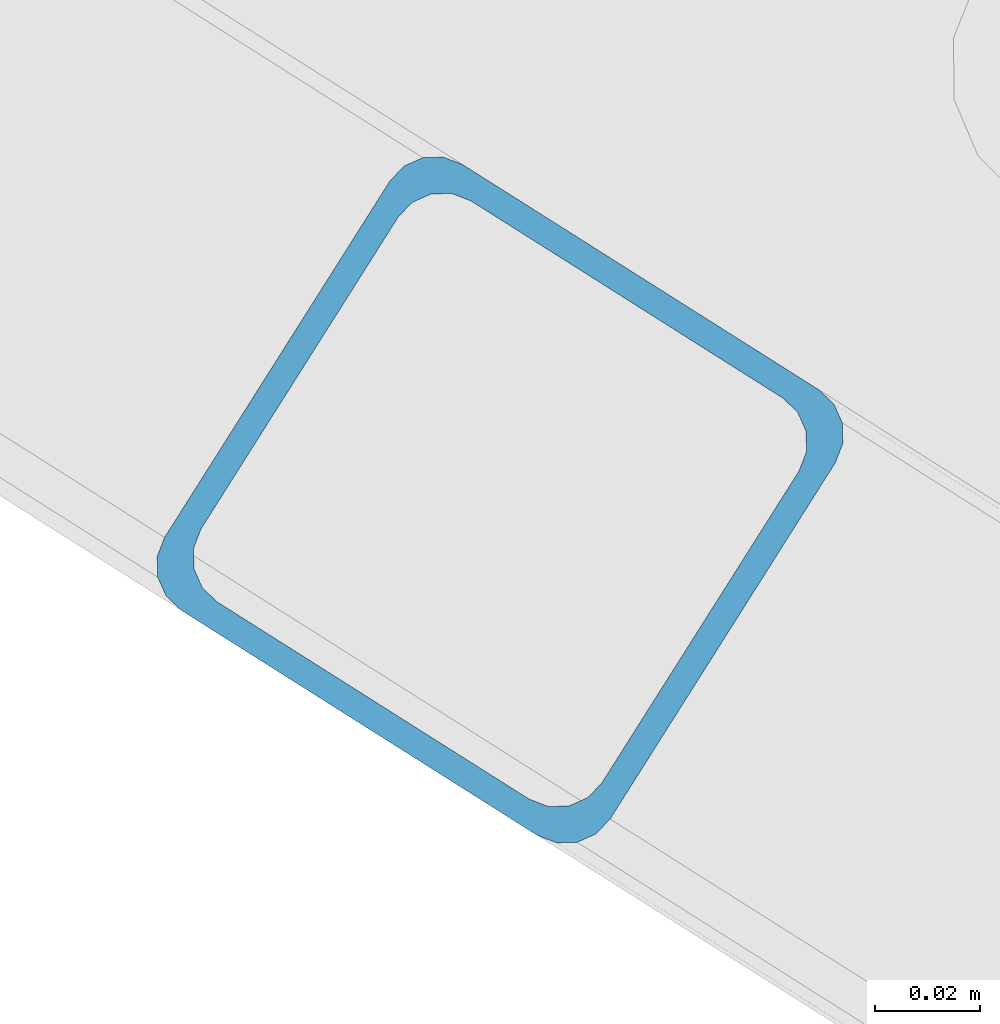
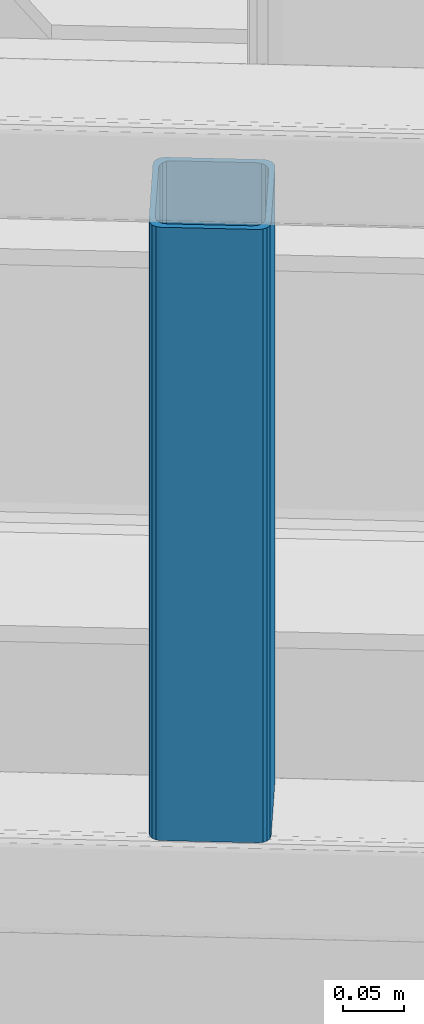
# One storey, part 12 of 92: 1 column.
"""IFC4 building model written with IfcOpenShell, lengths in millimetres."""

from ifc_helpers import new_model, entity, si_unit, converted_unit, derived_unit, direction, frame, origin, place, context, subcontext, project, spatial, indexed_curve, outline, extrude, type_object, element, save


model = new_model("IFC4")

# Units and contexts
model_context = context("Model", 3, precision=0.01, world=origin(), true_north=direction((6.12303176911189e-17, 1.0)))
plan_context = context("Plan", 3, precision=0.01, world=origin(), true_north=direction((6.12303176911189e-17, 1.0)))
body_context = subcontext(model_context, "Body", "Model", "MODEL_VIEW")
ifc_project = project(units=[si_unit("LENGTHUNIT", "METRE", prefix="MILLI"), si_unit("AREAUNIT", "SQUARE_METRE"), si_unit("VOLUMEUNIT", "CUBIC_METRE"), converted_unit("PLANEANGLEUNIT", "DEGREE", entity("IfcRatioMeasure", 0.0174532925199433), si_unit("PLANEANGLEUNIT", "RADIAN"), dimensions=[0, 0, 0, 0, 0, 0, 0]), si_unit("MASSUNIT", "GRAM", prefix="KILO"), derived_unit("MASSDENSITYUNIT", [(si_unit("MASSUNIT", "GRAM", prefix="KILO"), 1), (si_unit("LENGTHUNIT", "METRE"), -3)]), derived_unit("MOMENTOFINERTIAUNIT", [(si_unit("LENGTHUNIT", "METRE"), 4)]), si_unit("TIMEUNIT", "SECOND"), si_unit("FREQUENCYUNIT", "HERTZ"), si_unit("THERMODYNAMICTEMPERATUREUNIT", "DEGREE_CELSIUS"), derived_unit("THERMALTRANSMITTANCEUNIT", [(si_unit("MASSUNIT", "GRAM", prefix="KILO"), 1), (si_unit("THERMODYNAMICTEMPERATUREUNIT", "KELVIN"), -1), (si_unit("TIMEUNIT", "SECOND"), -3)]), derived_unit("VOLUMETRICFLOWRATEUNIT", [(si_unit("LENGTHUNIT", "METRE"), 3), (si_unit("TIMEUNIT", "SECOND"), -1)]), derived_unit("MASSFLOWRATEUNIT", [(si_unit("MASSUNIT", "GRAM", prefix="KILO"), 1), (si_unit("TIMEUNIT", "SECOND"), -1)]), derived_unit("ROTATIONALFREQUENCYUNIT", [(si_unit("TIMEUNIT", "SECOND"), -1)]), si_unit("ELECTRICCURRENTUNIT", "AMPERE"), si_unit("ELECTRICVOLTAGEUNIT", "VOLT"), si_unit("POWERUNIT", "WATT"), si_unit("FORCEUNIT", "NEWTON", prefix="KILO"), si_unit("ILLUMINANCEUNIT", "LUX"), si_unit("LUMINOUSFLUXUNIT", "LUMEN"), si_unit("LUMINOUSINTENSITYUNIT", "CANDELA"), derived_unit("USERDEFINED", [(si_unit("MASSUNIT", "GRAM", prefix="KILO"), -1), (si_unit("LENGTHUNIT", "METRE"), -2), (si_unit("TIMEUNIT", "SECOND"), 3), (si_unit("LUMINOUSFLUXUNIT", "LUMEN"), 1)]), derived_unit("LINEARVELOCITYUNIT", [(si_unit("LENGTHUNIT", "METRE"), 1), (si_unit("TIMEUNIT", "SECOND"), -1)]), si_unit("PRESSUREUNIT", "PASCAL"), derived_unit("USERDEFINED", [(si_unit("LENGTHUNIT", "METRE"), -2), (si_unit("MASSUNIT", "GRAM", prefix="KILO"), 1), (si_unit("TIMEUNIT", "SECOND"), -2)]), derived_unit("LINEARFORCEUNIT", [(si_unit("MASSUNIT", "GRAM", prefix="KILO"), 1), (si_unit("LENGTHUNIT", "METRE"), 1), (si_unit("TIMEUNIT", "SECOND"), -2), (si_unit("LENGTHUNIT", "METRE"), -1)]), derived_unit("PLANARFORCEUNIT", [(si_unit("MASSUNIT", "GRAM", prefix="KILO"), 1), (si_unit("LENGTHUNIT", "METRE"), 1), (si_unit("TIMEUNIT", "SECOND"), -2), (si_unit("LENGTHUNIT", "METRE"), -2)])], contexts=[model_context, plan_context])

# Site, building, storey
site_placement = place(None, origin())
site = spatial("IfcSite", under=ifc_project, at=site_placement, CompositionType="ELEMENT")
building_placement = place(site_placement, origin())
building = spatial("IfcBuilding", under=site, at=building_placement, CompositionType="ELEMENT")
storey_placement = place(building_placement, frame((0.0, 0.0, 15900.0)))
storey = spatial("IfcBuildingStorey", under=building, at=storey_placement, Name="05", CompositionType="ELEMENT", Elevation=15900.0)

# Column
column_type = type_object("IfcColumnType", PredefinedType="COLUMN")
column_placement = place(storey_placement, origin())
element("IfcColumn", 1, at=column_placement, inside=storey, type_object=column_type, ObjectType="Steel Column", PredefinedType="COLUMN", context=body_context, shape_type="SweptSolid", body=[
    extrude(outline(indexed_curve([(29.476895115338, -56.8428769007487), (33.3787015556669, -56.8428769007487), (36.983500665699, -55.3497202197336), (39.7424944585263, -52.5907264268981), (41.2356511395292, -48.9859273168578), (56.8428769008052, 29.4768951153998), (56.8428769008048, 33.3787015557219), (55.3497202198055, 36.9835006657402), (52.5907264269724, 39.74249445857), (48.9859273169345, 41.235651139574), (-29.4768951153382, 56.8428769007431), (-33.37870155566, 56.8428769007367), (-36.9835006657023, 55.349720219736), (-39.7424944585296, 52.5907264269006), (-41.2356511395375, 48.9859273168674), (-56.8428769008154, -29.4768951153913), (-56.8428769008082, -33.3787015557193), (-55.3497202198007, -36.9835006657526), (-52.5907264269706, -39.7424944585747), (-48.9859273169378, -41.2356511395715), (29.476895115338, -56.8428769007487)], self_intersect=False), holes=[indexed_curve([(-43.1065493048402, -37.3071763476223), (-46.7113484148819, -35.8140196666204), (-49.4703422077054, -33.0550258738095), (-50.9634988887191, -29.450226763778), (-50.9634988887132, -25.548420323448), (-37.3071763476002, 43.1065493047872), (-35.8140196665925, 46.711348414815), (-33.0550258737631, 49.4703422076511), (-29.4502267637347, 50.9634988886636), (-25.5484203234035, 50.9634988886758), (43.106549304837, 37.3071763476427), (46.7113484148668, 35.8140196666416), (49.4703422077049, 33.0550258737987), (50.9634988887123, 29.4502267637654), (50.9634988887072, 25.5484203234516), (37.3071763475942, -43.1065493047656), (35.8140196665845, -46.7113484148004), (33.0550258737589, -49.47034220764), (29.4502267637176, -50.9634988886433), (25.5484203234017, -50.963498888647), (-43.1065493048402, -37.3071763476223)], self_intersect=False)]), frame((-309.93, 12796.88, 3168.0), z_axis=(0.0, 0.0, 1.0), x_axis=(-0.35919409370256, -0.933262879926763, 0.0)), (0.0, 0.0, 1.0), 611.999999999935),
])

save(model, "model.ifc")
